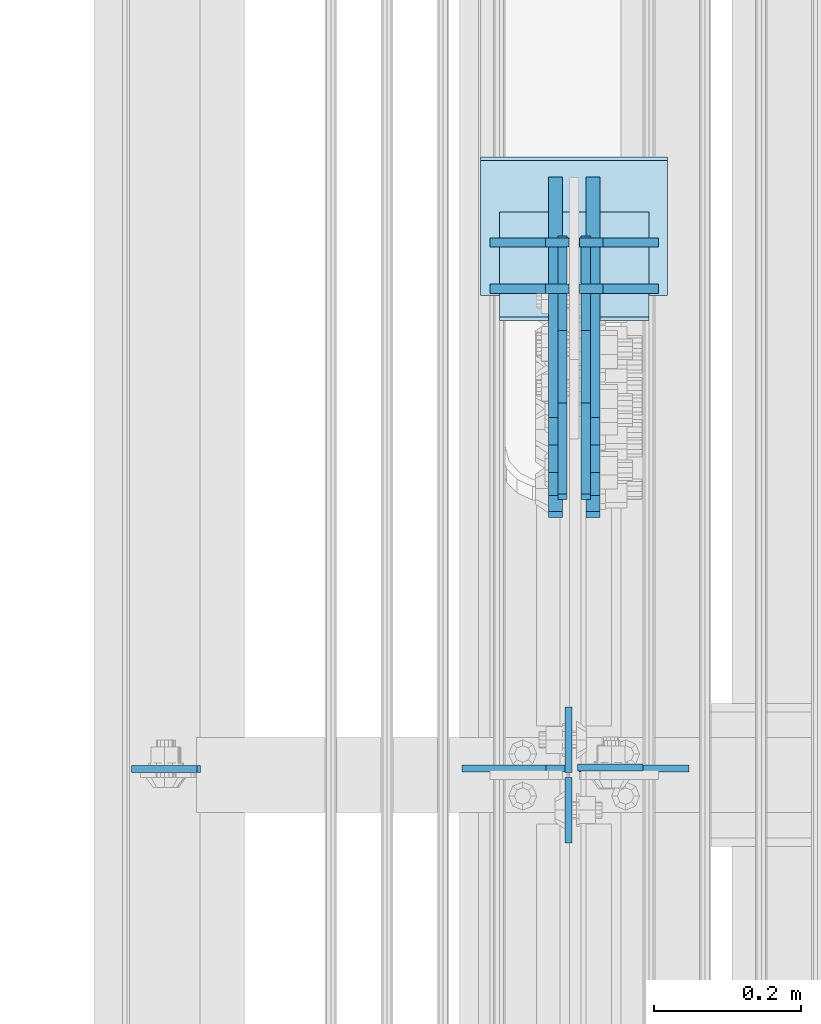
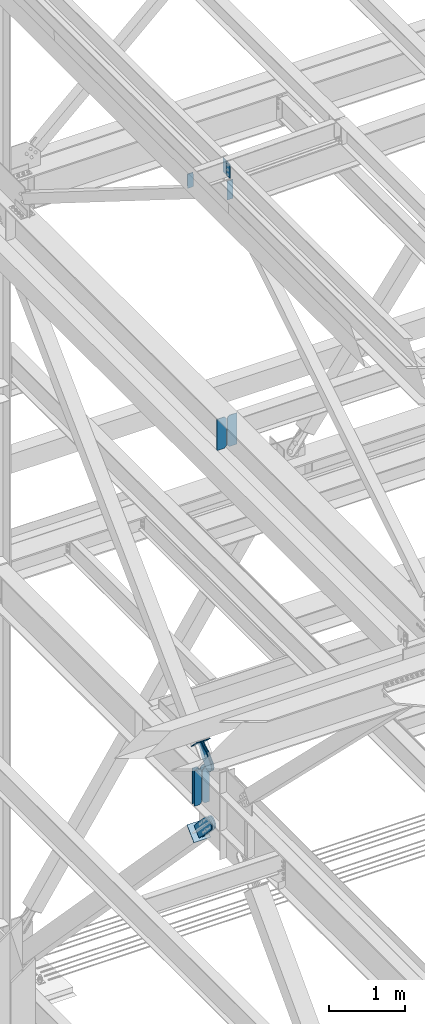
# One storey, part 3531 of 3843: 16 plates, 11 elements without a shape of their own.
"""IFC2X3 building model written with IfcOpenShell, lengths in millimetres."""

from ifc_helpers import new_model, si_unit, frame, origin_with_axes, place, context, subcontext, project, spatial, faceted_brep, material, type_object, element, aggregate, save


model = new_model("IFC2X3")

# Units and contexts
model_context = context("Model", 3, precision=1e-05, world=origin_with_axes())
body_context = subcontext(model_context, "Body", "Model", "MODEL_VIEW")
ifc_project = project(units=[si_unit("LENGTHUNIT", "METRE", prefix="MILLI"), si_unit("AREAUNIT", "SQUARE_METRE"), si_unit("VOLUMEUNIT", "CUBIC_METRE"), si_unit("MASSUNIT", "GRAM", prefix="KILO"), si_unit("TIMEUNIT", "SECOND"), si_unit("PLANEANGLEUNIT", "RADIAN"), si_unit("SOLIDANGLEUNIT", "STERADIAN"), si_unit("THERMODYNAMICTEMPERATUREUNIT", "DEGREE_CELSIUS"), si_unit("LUMINOUSINTENSITYUNIT", "LUMEN")], contexts=[model_context])

# Site, building, storey
site_placement = place(None, origin_with_axes())
site = spatial("IfcSite", under=ifc_project, at=site_placement, CompositionType="ELEMENT")
building_placement = place(site_placement, origin_with_axes())
building = spatial("IfcBuilding", under=site, at=building_placement, Name="Undefined", CompositionType="ELEMENT")
storey_placement = place(building_placement, origin_with_axes())
storey = spatial("IfcBuildingStorey", under=building, at=storey_placement, Name="Undefined", CompositionType="ELEMENT", Elevation=0.0)

# Assembly, plates
assembly_1_placement = place(storey_placement, origin_with_axes())
assembly_1 = element("IfcElementAssembly", 1, at=assembly_1_placement, inside=storey, Name="BEAM", AssemblyPlace="NOTDEFINED", PredefinedType="RIGID_FRAME")
ifc_material_1 = material(Name="STEEL/A572-50")
plate_type_1 = type_object("IfcPlateType", PredefinedType="NOTDEFINED")
plate_1_placement = place(assembly_1_placement, frame((77004.8625000115, 98383.7250000001, 46547.009193348), z_axis=(0.0, -1.0, 0.0), x_axis=(0.0, 0.0, -1.0)))
plate_1 = element("IfcPlate", 2, at=plate_1_placement, type_object=plate_type_1, material=ifc_material_1, Name="PLATE", context=body_context, shape_type="Brep", body=[
    faceted_brep([(0.0, -4.76249999999709, 0.0), (0.0, -4.76249999999709, 88.9000015258789), (0.0, 4.76249999999709, 88.9000015258789), (0.0, 4.76249999999709, 0.0), (228.600006102781, -4.7625000004191, 88.9000015257589), (228.600006102781, 4.76249999954598, 88.9000015257443), (228.600006103079, -4.7625000004482, 7.27595761418343e-12), (228.600006103079, 4.76249999954598, -7.27595761418343e-12)], [[[0, 1, 2, 3]], [[1, 4, 5, 2]], [[4, 6, 7, 5]], [[6, 0, 3, 7]], [[5, 7, 3, 2]], [[6, 4, 1, 0]]]),
])
plate_2_placement = place(assembly_1_placement, frame((77004.8625000148, 98390.0750000001, 46547.0091933484), z_axis=(0.0, 1.0, 0.0), x_axis=(0.0, 0.0, -1.0)))
plate_2 = element("IfcPlate", 3, at=plate_2_placement, type_object=plate_type_1, material=ifc_material_1, Name="PLATE", context=body_context, shape_type="Brep", body=[
    faceted_brep([(0.0, -4.76249999999709, 0.0), (0.0, -4.76249999999709, 88.9000015258789), (0.0, 4.76249999999709, 88.9000015258789), (0.0, 4.76249999999709, 0.0), (228.600006102781, -4.7625000004191, 88.9000015257589), (228.600006102781, 4.76249999954598, 88.9000015257443), (228.600006103079, -4.7625000004482, 7.27595761418343e-12), (228.600006103079, 4.76249999954598, -7.27595761418343e-12)], [[[0, 1, 2, 3]], [[1, 4, 5, 2]], [[4, 6, 7, 5]], [[6, 0, 3, 7]], [[5, 7, 3, 2]], [[6, 4, 1, 0]]]),
])
aggregate(assembly_1, [plate_1, plate_2])

# Assembly, plate
assembly_2_placement = place(storey_placement, origin_with_axes())
assembly_2 = element("IfcElementAssembly", 4, at=assembly_2_placement, inside=storey, Name="CHANNEL", AssemblyPlace="NOTDEFINED", PredefinedType="RIGID_FRAME")
plate_3_placement = place(assembly_2_placement, frame((76411.9416190429, 98394.8375000001, 46534.2884082077), z_axis=(0.999776270257024, 0.0, 0.0211520550054619), x_axis=(0.0211520550054438, 0.0, -0.999776270257025)))
plate_3 = element("IfcPlate", 5, at=plate_3_placement, type_object=plate_type_1, material=ifc_material_1, Name="PLATE", context=body_context, shape_type="Brep", body=[
    faceted_brep([(0.0, -4.76249999999709, 0.0), (0.0, -4.76249999999709, 88.9000015258789), (0.0, 4.76249999999709, 88.9000015258789), (0.0, 4.76249999999709, 0.0), (228.600006102781, -4.7625000004191, 88.9000015257589), (228.600006102781, 4.76249999954598, 88.9000015257443), (228.600006103079, -4.7625000004482, 7.27595761418343e-12), (228.600006103079, 4.76249999954598, -7.27595761418343e-12)], [[[0, 1, 2, 3]], [[1, 4, 5, 2]], [[4, 6, 7, 5]], [[6, 0, 3, 7]], [[5, 7, 3, 2]], [[6, 4, 1, 0]]]),
])
aggregate(assembly_2, [plate_3])

assembly_3_placement = place(storey_placement, origin_with_axes())
assembly_3 = element("IfcElementAssembly", 6, at=assembly_3_placement, inside=storey, Name="BEAM", AssemblyPlace="NOTDEFINED", PredefinedType="RIGID_FRAME")
plate_4_placement = place(assembly_3_placement, frame((77017.5625, 98397.21875, 46211.4080239933), z_axis=(1.0, 0.0, 0.0), x_axis=(0.0, 0.0, -1.0)))
plate_4 = element("IfcPlate", 7, at=plate_4_placement, type_object=plate_type_1, material=ifc_material_1, Name="PLATE", context=body_context, shape_type="Brep", body=[
    faceted_brep([(0.0, -4.76249999999709, 0.0), (0.0, -4.76249999999709, 88.9000015258789), (0.0, 4.76249999999709, 88.9000015258789), (0.0, 4.76249999999709, 0.0), (304.800000000003, -4.76249999999709, 88.8999999999942), (304.800000000003, 4.76249999999709, 88.8999999999942), (304.800000000003, -4.76249999999709, 0.0), (304.800000000003, 4.76249999999709, 0.0)], [[[0, 1, 2, 3]], [[1, 4, 5, 2]], [[4, 6, 7, 5]], [[6, 0, 3, 7]], [[5, 7, 3, 2]], [[6, 4, 1, 0]]]),
])
aggregate(assembly_3, [plate_4])

# Assembly, plates
assembly_4_placement = place(storey_placement, origin_with_axes())
assembly_4 = element("IfcElementAssembly", 8, at=assembly_4_placement, inside=storey, Name="BEAM", AssemblyPlace="NOTDEFINED", PredefinedType="RIGID_FRAME")
plate_type_2 = type_object("IfcPlateType", PredefinedType="NOTDEFINED")
plate_5_placement = place(assembly_4_placement, frame((77019.15, 98395.6317499161, 41946.5125), z_axis=(0.0, 0.0, 1.0), x_axis=(1.0, 0.0, 0.0)))
plate_5 = element("IfcPlate", 9, at=plate_5_placement, type_object=plate_type_2, material=ifc_material_1, Name="PLATE", context=body_context, shape_type="Brep", body=[
    faceted_brep([(0.0, -4.76249999999709, 31.75), (0.0, -4.76250000000073, 469.900000000001), (0.0, 4.76250000000073, 469.900000000001), (0.0, 4.76249999999709, 31.75), (31.75, -4.76250000000073, 501.650000000001), (31.75, 4.76250000000073, 501.650000000001), (149.224999999991, -4.76250000000073, 501.650000000001), (149.224999999991, 4.76250000000073, 501.650000000001), (149.224999999977, -4.76249999999709, 0.0), (149.224999999977, 4.76249999999709, 0.0), (31.75, -4.76249999999709, 0.0), (31.75, 4.76249999999709, 0.0)], [[[0, 1, 2, 3]], [[1, 4, 5, 2]], [[4, 6, 7, 5]], [[6, 8, 9, 7]], [[8, 10, 11, 9]], [[10, 0, 3, 11]], [[5, 7, 9, 11, 3, 2]], [[10, 8, 6, 4, 1, 0]]]),
])
plate_type_3 = type_object("IfcPlateType", PredefinedType="NOTDEFINED")
plate_6_placement = place(assembly_4_placement, frame((77006.45, 98395.6317499161, 41946.5125), z_axis=(0.0, 0.0, 1.0), x_axis=(-1.0, 0.0, 0.0)))
plate_6 = element("IfcPlate", 10, at=plate_6_placement, type_object=plate_type_3, material=ifc_material_1, Name="PLATE", context=body_context, shape_type="Brep", body=[
    faceted_brep([(0.0, -4.76249999999709, 31.75), (0.0, -4.76250000000073, 469.900000000001), (0.0, 4.76250000000073, 469.900000000001), (0.0, 4.76249999999709, 31.75), (31.75, -4.76250000000073, 501.650000000001), (31.75, 4.76250000000073, 501.650000000001), (146.049999999988, -4.76250000000073, 501.650000000001), (146.049999999988, 4.76250000000073, 501.650000000001), (146.049999999988, -4.76250000000073, 0.0), (146.049999999988, 4.76250000000073, 0.0), (31.75, -4.76249999999709, 0.0), (31.75, 4.76249999999709, 0.0)], [[[0, 1, 2, 3]], [[1, 4, 5, 2]], [[4, 6, 7, 5]], [[6, 8, 9, 7]], [[8, 10, 11, 9]], [[10, 0, 3, 11]], [[5, 7, 9, 11, 3, 2]], [[10, 8, 6, 4, 1, 0]]]),
])
aggregate(assembly_4, [plate_6, plate_5])

assembly_5_placement = place(storey_placement, origin_with_axes())
assembly_5 = element("IfcElementAssembly", 11, at=assembly_5_placement, inside=storey, Name="BEAM", AssemblyPlace="NOTDEFINED", PredefinedType="RIGID_FRAME")
plate_type_4 = type_object("IfcPlateType", PredefinedType="NOTDEFINED")
plate_7_placement = place(assembly_5_placement, frame((77005.65625, 99109.7316095365, 35840.9875), z_axis=(-1.0, 0.0, 0.0), x_axis=(0.0, 0.0, 1.0)))
plate_7 = element("IfcPlate", 12, at=plate_7_placement, type_object=plate_type_4, material=ifc_material_1, Name="CB_BEAM", context=body_context, shape_type="Brep", body=[
    faceted_brep([(0.0, -6.35000000000582, 31.75), (0.0, -6.35000000000582, 107.15625), (0.0, 6.35000000000582, 107.15625), (0.0, 6.35000000000582, 31.75), (568.324999999997, -6.35000000000582, 107.15625), (568.324999999997, 6.35000000000582, 107.15625), (568.324999999997, -6.35000000000582, 31.75), (568.324999999997, 6.35000000000582, 31.75), (536.574999999997, -6.35000000000582, 0.0), (536.574999999997, 6.35000000000582, 0.0), (31.75, -6.35000000000582, 0.0), (31.75, 6.35000000000582, 0.0)], [[[0, 1, 2, 3]], [[1, 4, 5, 2]], [[4, 6, 7, 5]], [[6, 8, 9, 7]], [[8, 10, 11, 9]], [[10, 0, 3, 11]], [[5, 7, 9, 11, 3, 2]], [[10, 8, 6, 4, 1, 0]]]),
])
plate_8_placement = place(assembly_5_placement, frame((77019.94375, 99109.7316095365, 35840.9875), z_axis=(1.0, 0.0, 0.0), x_axis=(0.0, 0.0, 1.0)))
plate_8 = element("IfcPlate", 13, at=plate_8_placement, type_object=plate_type_4, material=ifc_material_1, Name="CB_BEAM", context=body_context, shape_type="Brep", body=[
    faceted_brep([(0.0, -6.35000000000582, 31.75), (0.0, -6.35000000000582, 107.15625), (0.0, 6.35000000000582, 107.15625), (0.0, 6.35000000000582, 31.75), (568.324999999997, -6.35000000000582, 107.15625), (568.324999999997, 6.35000000000582, 107.15625), (568.324999999997, -6.35000000000582, 31.75), (568.324999999997, 6.35000000000582, 31.75), (536.574999999997, -6.35000000000582, 0.0), (536.574999999997, 6.35000000000582, 0.0), (31.75, -6.35000000000582, 0.0), (31.75, 6.35000000000582, 0.0)], [[[0, 1, 2, 3]], [[1, 4, 5, 2]], [[4, 6, 7, 5]], [[6, 8, 9, 7]], [[8, 10, 11, 9]], [[10, 0, 3, 11]], [[5, 7, 9, 11, 3, 2]], [[10, 8, 6, 4, 1, 0]]]),
])
plate_9_placement = place(assembly_5_placement, frame((77005.65625, 99047.1076742764, 35840.9875), z_axis=(-1.0, 0.0, 0.0), x_axis=(0.0, 0.0, 1.0)))
plate_9 = element("IfcPlate", 14, at=plate_9_placement, type_object=plate_type_4, material=ifc_material_1, Name="CB_BEAM", context=body_context, shape_type="Brep", body=[
    faceted_brep([(0.0, -6.35000000000582, 31.75), (0.0, -6.35000000000582, 107.15625), (0.0, 6.35000000000582, 107.15625), (0.0, 6.35000000000582, 31.75), (568.324999999997, -6.35000000000582, 107.15625), (568.324999999997, 6.35000000000582, 107.15625), (568.324999999997, -6.35000000000582, 31.75), (568.324999999997, 6.35000000000582, 31.75), (536.574999999997, -6.35000000000582, 0.0), (536.574999999997, 6.35000000000582, 0.0), (31.75, -6.35000000000582, 0.0), (31.75, 6.35000000000582, 0.0)], [[[0, 1, 2, 3]], [[1, 4, 5, 2]], [[4, 6, 7, 5]], [[6, 8, 9, 7]], [[8, 10, 11, 9]], [[10, 0, 3, 11]], [[5, 7, 9, 11, 3, 2]], [[10, 8, 6, 4, 1, 0]]]),
])
plate_10_placement = place(assembly_5_placement, frame((77019.94375, 99047.1076742764, 35840.9875), z_axis=(1.0, 0.0, 0.0), x_axis=(0.0, 0.0, 1.0)))
plate_10 = element("IfcPlate", 15, at=plate_10_placement, type_object=plate_type_4, material=ifc_material_1, Name="CB_BEAM", context=body_context, shape_type="Brep", body=[
    faceted_brep([(0.0, -6.35000000000582, 31.75), (0.0, -6.35000000000582, 107.15625), (0.0, 6.35000000000582, 107.15625), (0.0, 6.35000000000582, 31.75), (568.324999999997, -6.35000000000582, 107.15625), (568.324999999997, 6.35000000000582, 107.15625), (568.324999999997, -6.35000000000582, 31.75), (568.324999999997, 6.35000000000582, 31.75), (536.574999999997, -6.35000000000582, 0.0), (536.574999999997, 6.35000000000582, 0.0), (31.75, -6.35000000000582, 0.0), (31.75, 6.35000000000582, 0.0)], [[[0, 1, 2, 3]], [[1, 4, 5, 2]], [[4, 6, 7, 5]], [[6, 8, 9, 7]], [[8, 10, 11, 9]], [[10, 0, 3, 11]], [[5, 7, 9, 11, 3, 2]], [[10, 8, 6, 4, 1, 0]]]),
])
aggregate(assembly_5, [plate_7, plate_8, plate_9, plate_10])

# Assembly, plate
assembly_6_placement = place(storey_placement, origin_with_axes())
assembly_6 = element("IfcElementAssembly", 16, at=assembly_6_placement, inside=storey, Name="Plate", AssemblyPlace="NOTDEFINED", PredefinedType="RIGID_FRAME")
ifc_material_2 = material(Name="STEEL/A36")
plate_type_5 = type_object("IfcPlateType", PredefinedType="NOTDEFINED")
plate_11_placement = place(assembly_6_placement, frame((77114.4, 99148.4673806973, 36731.8524225172), z_axis=(0.0, -0.701307718956745, 0.712858669956175), x_axis=(-1.0, 0.0, 0.0)))
plate_11 = element("IfcPlate", 17, at=plate_11_placement, type_object=plate_type_5, material=ifc_material_2, Name="Plate", context=body_context, shape_type="Brep", body=[
    faceted_brep([(0.0, -3.17499999999927, 0.0), (0.0, -3.17500000043947, 203.200000001736), (0.0, 3.1749999995518, 203.200000001743), (0.0, 3.17499999999927, 0.0), (203.200000000012, -3.17500000043947, 203.200000001736), (203.200000000012, 3.1749999995518, 203.200000001743), (203.199996948242, -3.17499999999927, 0.0), (203.199996948242, 3.17499999999927, 0.0)], [[[0, 1, 2, 3]], [[1, 4, 5, 2]], [[4, 6, 7, 5]], [[6, 0, 3, 7]], [[5, 7, 3, 2]], [[6, 4, 1, 0]]]),
])
aggregate(assembly_6, [plate_11])

assembly_7_placement = place(storey_placement, origin_with_axes())
assembly_7 = element("IfcElementAssembly", 18, at=assembly_7_placement, inside=storey, AssemblyPlace="NOTDEFINED", PredefinedType="RIGID_FRAME")
plate_type_6 = type_object("IfcPlateType", PredefinedType="NOTDEFINED")
plate_12_placement = place(assembly_7_placement, frame((76987.4, 99150.3378756837, 35459.2492894834), z_axis=(0.0, -0.721558108087918, -0.692353881084366), x_axis=(0.0, 0.692353881084366, -0.721558108087918)))
plate_12 = element("IfcPlate", 19, at=plate_12_placement, type_object=plate_type_6, material=ifc_material_2, context=body_context, shape_type="Brep", body=[
    faceted_brep([(0.0, -9.52500000000146, 0.0), (-101.59999999866, -9.52499999999418, -7.01164927375794), (-101.59999999866, 9.52499999999418, -7.01164927375794), (0.0, 9.52500000000146, 0.0), (-364.729297655074, -9.52499999999418, -7.01164927444188), (-364.729297655074, 9.52499999999418, -7.01164927444188), (-401.787405121293, -9.52499999999418, 0.359666612348519), (-401.787405121293, 9.52499999999418, 0.359666612348519), (-433.203751657995, -9.52499999999418, 21.3513982502482), (-433.203751657995, 9.52499999999418, 21.3513982502482), (-454.195483294687, -9.52499999999418, 52.7677447877504), (-454.195483294687, 9.52499999999418, 52.7677447877504), (-461.566799180051, -9.52499999999418, 89.8258492000314), (-461.566799180051, 9.52499999999418, 89.8258492000314), (-454.195483292249, -9.52499999999418, 126.883956664562), (-454.195483292249, 9.52499999999418, 126.883956664562), (-433.203751654662, -9.52499999999418, 158.300303199998), (-433.203751654662, 9.52499999999418, 158.300303199998), (-401.787405118426, -9.52499999999418, 179.292034836384), (-401.787405118426, 9.52499999999418, 179.292034836384), (-364.729299177612, -9.52499999999418, 186.663350722738), (-364.729299177612, 9.52499999999418, 186.663350722738), (-101.5999999907, -9.52499999999418, 186.663350723451), (-101.5999999907, 9.52499999999418, 186.663350723451), (7.37782102078199e-09, -9.52499999999418, 179.651701450231), (7.37782102078199e-09, 9.52499999999418, 179.651701450231), (69.8500000062704, -9.52499999999418, 179.651701450392), (69.8500000062704, 9.52499999999418, 179.651701450392), (69.8499999979995, -9.52499999999418, -4.00177668780088e-10), (69.8499999979995, 9.52499999999418, -4.00177668780088e-10)], [[[0, 1, 2, 3]], [[1, 4, 5, 2]], [[4, 6, 7, 5]], [[6, 8, 9, 7]], [[8, 10, 11, 9]], [[10, 12, 13, 11]], [[12, 14, 15, 13]], [[14, 16, 17, 15]], [[16, 18, 19, 17]], [[18, 20, 21, 19]], [[20, 22, 23, 21]], [[22, 24, 25, 23]], [[24, 26, 27, 25]], [[26, 28, 29, 27]], [[28, 0, 3, 29]], [[5, 7, 9, 11, 13, 15, 17, 19, 21, 23, 25, 27, 29, 3, 2]], [[28, 26, 24, 22, 20, 18, 16, 14, 12, 10, 8, 6, 4, 1, 0]]]),
])
aggregate(assembly_7, [plate_12])

assembly_8_placement = place(storey_placement, origin_with_axes())
assembly_8 = element("IfcElementAssembly", 20, at=assembly_8_placement, inside=storey, AssemblyPlace="NOTDEFINED", PredefinedType="RIGID_FRAME")
plate_13_placement = place(assembly_8_placement, frame((77038.2, 99150.3378756837, 35459.2492894834), z_axis=(0.0, -0.721558108087918, -0.692353881084366), x_axis=(0.0, 0.692353881084366, -0.721558108087918)))
plate_13 = element("IfcPlate", 21, at=plate_13_placement, type_object=plate_type_6, material=ifc_material_2, context=body_context, shape_type="Brep", body=[
    faceted_brep([(0.0, -9.52500000000146, 0.0), (-101.59999999866, -9.52499999999418, -7.01164927375794), (-101.59999999866, 9.52499999999418, -7.01164927375794), (0.0, 9.52500000000146, 0.0), (-364.729297655074, -9.52499999999418, -7.01164927444188), (-364.729297655074, 9.52499999999418, -7.01164927444188), (-401.787405121293, -9.52499999999418, 0.359666612348519), (-401.787405121293, 9.52499999999418, 0.359666612348519), (-433.203751657995, -9.52499999999418, 21.3513982502482), (-433.203751657995, 9.52499999999418, 21.3513982502482), (-454.195483294687, -9.52499999999418, 52.7677447877504), (-454.195483294687, 9.52499999999418, 52.7677447877504), (-461.566799180051, -9.52499999999418, 89.8258492000314), (-461.566799180051, 9.52499999999418, 89.8258492000314), (-454.195483292249, -9.52499999999418, 126.883956664562), (-454.195483292249, 9.52499999999418, 126.883956664562), (-433.203751654662, -9.52499999999418, 158.300303199998), (-433.203751654662, 9.52499999999418, 158.300303199998), (-401.787405118426, -9.52499999999418, 179.292034836384), (-401.787405118426, 9.52499999999418, 179.292034836384), (-364.729299177612, -9.52499999999418, 186.663350722738), (-364.729299177612, 9.52499999999418, 186.663350722738), (-101.5999999907, -9.52499999999418, 186.663350723451), (-101.5999999907, 9.52499999999418, 186.663350723451), (7.37782102078199e-09, -9.52499999999418, 179.651701450231), (7.37782102078199e-09, 9.52499999999418, 179.651701450231), (69.8500000062704, -9.52499999999418, 179.651701450392), (69.8500000062704, 9.52499999999418, 179.651701450392), (69.8499999979995, -9.52499999999418, -4.00177668780088e-10), (69.8499999979995, 9.52499999999418, -4.00177668780088e-10)], [[[0, 1, 2, 3]], [[1, 4, 5, 2]], [[4, 6, 7, 5]], [[6, 8, 9, 7]], [[8, 10, 11, 9]], [[10, 12, 13, 11]], [[12, 14, 15, 13]], [[14, 16, 17, 15]], [[16, 18, 19, 17]], [[18, 20, 21, 19]], [[20, 22, 23, 21]], [[22, 24, 25, 23]], [[24, 26, 27, 25]], [[26, 28, 29, 27]], [[28, 0, 3, 29]], [[5, 7, 9, 11, 13, 15, 17, 19, 21, 23, 25, 27, 29, 3, 2]], [[28, 26, 24, 22, 20, 18, 16, 14, 12, 10, 8, 6, 4, 1, 0]]]),
])
aggregate(assembly_8, [plate_13])

assembly_9_placement = place(storey_placement, origin_with_axes())
assembly_9 = element("IfcElementAssembly", 22, at=assembly_9_placement, inside=storey, Name="Plate", AssemblyPlace="NOTDEFINED", PredefinedType="RIGID_FRAME")
plate_type_7 = type_object("IfcPlateType", PredefinedType="NOTDEFINED")
plate_14_placement = place(assembly_9_placement, frame((76885.8, 99040.0481203439, 35261.0191836465), z_axis=(0.0, 0.721558108087918, 0.692353881084366), x_axis=(1.0, 0.0, 0.0)))
plate_14 = element("IfcPlate", 23, at=plate_14_placement, type_object=plate_type_7, material=ifc_material_2, Name="Plate", context=body_context, shape_type="Brep", body=[
    faceted_brep([(0.0, -3.17499999999927, 0.0), (0.0, -3.17499999965185, 254.000000005151), (0.0, 3.17500000035216, 254.000000005166), (0.0, 3.17499999999927, 0.0), (254.0, -3.17499999965185, 254.000000005151), (254.0, 3.17500000035216, 254.000000005166), (254.0, -3.17500000000291, 0.0), (254.0, 3.17499999999927, 1.45519152283669e-11)], [[[0, 1, 2, 3]], [[1, 4, 5, 2]], [[4, 6, 7, 5]], [[6, 0, 3, 7]], [[5, 7, 3, 2]], [[6, 4, 1, 0]]]),
])
aggregate(assembly_9, [plate_14])

assembly_10_placement = place(storey_placement, origin_with_axes())
assembly_10 = element("IfcElementAssembly", 24, at=assembly_10_placement, inside=storey, AssemblyPlace="NOTDEFINED", PredefinedType="RIGID_FRAME")
plate_type_8 = type_object("IfcPlateType", PredefinedType="NOTDEFINED")
plate_15_placement = place(assembly_10_placement, frame((76996.925, 99069.022743821, 36717.5331707194), z_axis=(0.0, -0.701307718956745, 0.712858669956175), x_axis=(0.0, 0.712858669956106, 0.701307718956815)))
plate_15 = element("IfcPlate", 25, at=plate_15_placement, type_object=plate_type_8, material=ifc_material_2, context=body_context, shape_type="Brep", body=[
    faceted_brep([(0.0, -6.3499999046162, 0.0), (-101.600000000049, -6.35000000000582, -37.5700346004523), (-101.600000000049, 6.35000000000582, -37.5700346004523), (7.27595761418343e-12, 6.3499999046162, 0.0), (-245.369242325265, -6.35000000000582, -37.5700346003141), (-245.369242325265, 6.35000000000582, -37.5700346003141), (-281.212328726207, -6.35000000000582, -30.4404014297979), (-281.212328726207, 6.35000000000582, -30.4404014297979), (-311.59863014071, -6.35000000000582, -10.1369239383566), (-311.59863014071, 6.35000000000582, -10.1369239383566), (-331.902107630653, -6.35000000000582, 20.2493774772229), (-331.902107630653, 6.35000000000582, 20.2493774772229), (-339.031740799503, -6.35000000000582, 56.0924669294036), (-339.031740799503, 6.35000000000582, 56.0924669294036), (-331.902107628353, -6.35000000000582, 91.9355533280759), (-331.902107628353, 6.35000000000582, 91.9355533280759), (-311.598630138033, -6.35000000000582, 122.321854740563), (-311.598630138033, 6.35000000000582, 122.321854740563), (-281.212328724767, -6.35000000000582, 142.625332229603), (-281.212328724767, 6.35000000000582, 142.625332229603), (-245.369240796863, -6.35000000000582, 149.754965399145), (-245.369240796863, 6.35000000000582, 149.754965399145), (-101.599999991755, -6.35000000000582, 149.754965398992), (-101.599999991755, 6.35000000000582, 149.754965398992), (4.9622030928731e-09, -6.35000000000582, 112.184930798256), (4.9622030928731e-09, 6.35000000000582, 112.184930798256), (69.8500000038475, -6.35000000000582, 112.184930798168), (69.8500000038475, 6.35000000000582, 112.184930798168), (69.8499999985434, -6.35000000000582, -8.73114913702011e-11), (69.8499999985434, 6.35000000000582, -8.73114913702011e-11)], [[[0, 1, 2, 3]], [[1, 4, 5, 2]], [[4, 6, 7, 5]], [[6, 8, 9, 7]], [[8, 10, 11, 9]], [[10, 12, 13, 11]], [[12, 14, 15, 13]], [[14, 16, 17, 15]], [[16, 18, 19, 17]], [[18, 20, 21, 19]], [[20, 22, 23, 21]], [[22, 24, 25, 23]], [[24, 26, 27, 25]], [[26, 28, 29, 27]], [[28, 0, 3, 29]], [[5, 7, 9, 11, 13, 15, 17, 19, 21, 23, 25, 27, 29, 3, 2]], [[28, 26, 24, 22, 20, 18, 16, 14, 12, 10, 8, 6, 4, 1, 0]]]),
])
aggregate(assembly_10, [plate_15])

assembly_11_placement = place(storey_placement, origin_with_axes())
assembly_11 = element("IfcElementAssembly", 26, at=assembly_11_placement, inside=storey, AssemblyPlace="NOTDEFINED", PredefinedType="RIGID_FRAME")
plate_16_placement = place(assembly_11_placement, frame((77028.675, 99069.022743821, 36717.5331707194), z_axis=(0.0, -0.701307718956745, 0.712858669956175), x_axis=(0.0, 0.712858669956106, 0.701307718956815)))
plate_16 = element("IfcPlate", 27, at=plate_16_placement, type_object=plate_type_8, material=ifc_material_2, context=body_context, shape_type="Brep", body=[
    faceted_brep([(0.0, -6.3499999046162, 0.0), (-101.600000000049, -6.35000000000582, -37.5700346004523), (-101.600000000049, 6.35000000000582, -37.5700346004523), (7.27595761418343e-12, 6.3499999046162, 0.0), (-245.369242325265, -6.35000000000582, -37.5700346003141), (-245.369242325265, 6.35000000000582, -37.5700346003141), (-281.212328726207, -6.35000000000582, -30.4404014297979), (-281.212328726207, 6.35000000000582, -30.4404014297979), (-311.59863014071, -6.35000000000582, -10.1369239383566), (-311.59863014071, 6.35000000000582, -10.1369239383566), (-331.902107630653, -6.35000000000582, 20.2493774772229), (-331.902107630653, 6.35000000000582, 20.2493774772229), (-339.031740799503, -6.35000000000582, 56.0924669294036), (-339.031740799503, 6.35000000000582, 56.0924669294036), (-331.902107628353, -6.35000000000582, 91.9355533280759), (-331.902107628353, 6.35000000000582, 91.9355533280759), (-311.598630138033, -6.35000000000582, 122.321854740563), (-311.598630138033, 6.35000000000582, 122.321854740563), (-281.212328724767, -6.35000000000582, 142.625332229603), (-281.212328724767, 6.35000000000582, 142.625332229603), (-245.369240796863, -6.35000000000582, 149.754965399145), (-245.369240796863, 6.35000000000582, 149.754965399145), (-101.599999991755, -6.35000000000582, 149.754965398992), (-101.599999991755, 6.35000000000582, 149.754965398992), (4.9622030928731e-09, -6.35000000000582, 112.184930798256), (4.9622030928731e-09, 6.35000000000582, 112.184930798256), (69.8500000038475, -6.35000000000582, 112.184930798168), (69.8500000038475, 6.35000000000582, 112.184930798168), (69.8499999985434, -6.35000000000582, -8.73114913702011e-11), (69.8499999985434, 6.35000000000582, -8.73114913702011e-11)], [[[0, 1, 2, 3]], [[1, 4, 5, 2]], [[4, 6, 7, 5]], [[6, 8, 9, 7]], [[8, 10, 11, 9]], [[10, 12, 13, 11]], [[12, 14, 15, 13]], [[14, 16, 17, 15]], [[16, 18, 19, 17]], [[18, 20, 21, 19]], [[20, 22, 23, 21]], [[22, 24, 25, 23]], [[24, 26, 27, 25]], [[26, 28, 29, 27]], [[28, 0, 3, 29]], [[5, 7, 9, 11, 13, 15, 17, 19, 21, 23, 25, 27, 29, 3, 2]], [[28, 26, 24, 22, 20, 18, 16, 14, 12, 10, 8, 6, 4, 1, 0]]]),
])
aggregate(assembly_11, [plate_16])

save(model, "model.ifc")
